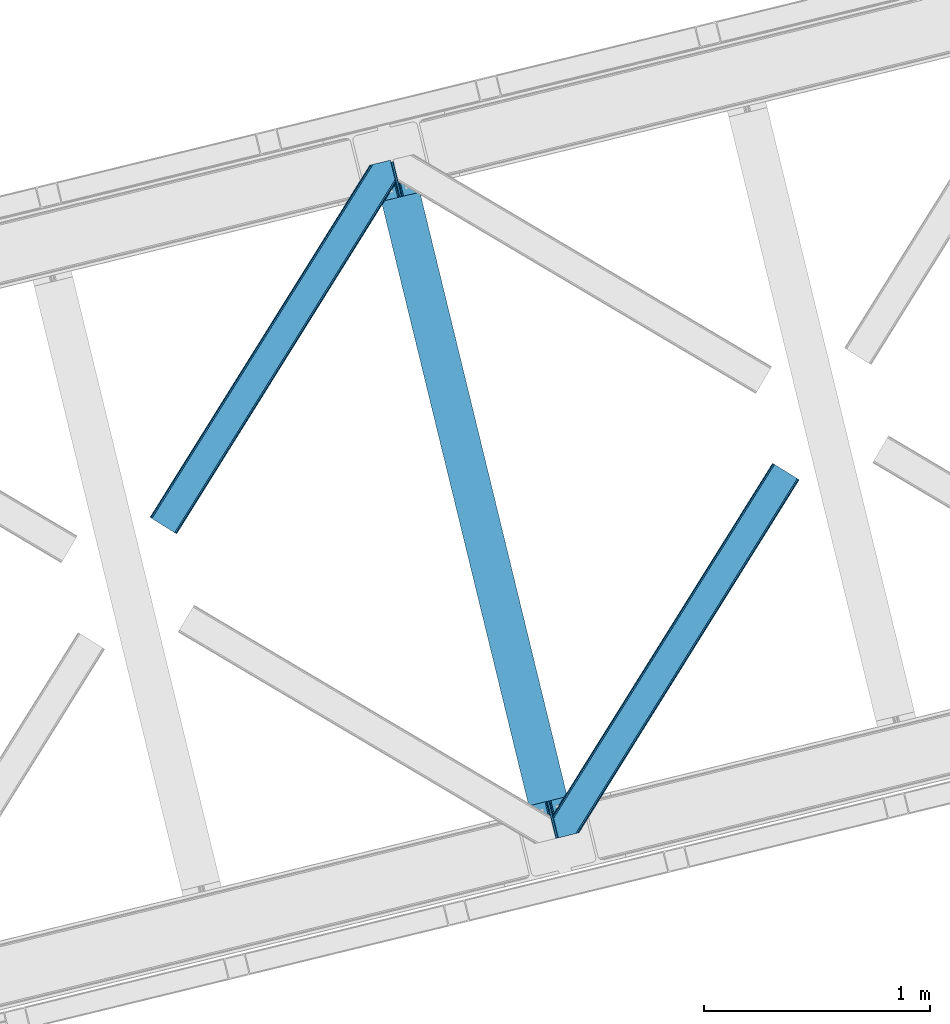
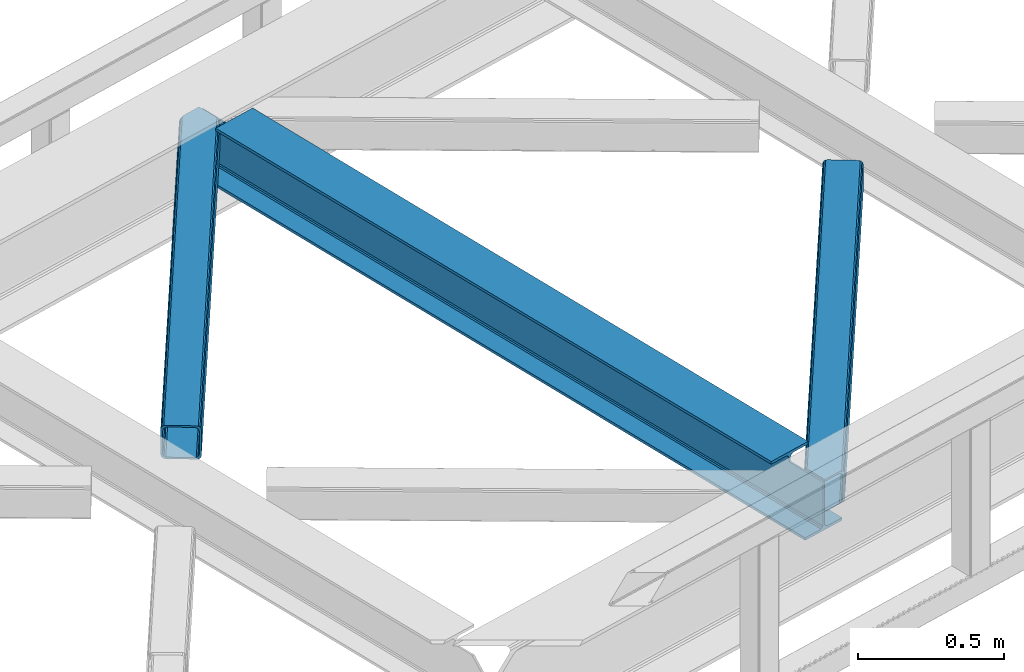
# One storey, part 60 of 92: 2 members, 1 beam.
"""IFC4 building model written with IfcOpenShell, lengths in millimetres."""

from ifc_helpers import new_model, entity, si_unit, converted_unit, derived_unit, direction, frame, origin, place, context, subcontext, project, spatial, triangles, polygons, material, type_object, element, save


model = new_model("IFC4")

# Units and contexts
model_context = context("Model", 3, precision=0.01, world=origin(), true_north=direction((6.12303176911189e-17, 1.0)))
plan_context = context("Plan", 3, precision=0.01, world=origin(), true_north=direction((6.12303176911189e-17, 1.0)))
body_context = subcontext(model_context, "Body", "Model", "MODEL_VIEW")
ifc_project = project(units=[si_unit("LENGTHUNIT", "METRE", prefix="MILLI"), si_unit("AREAUNIT", "SQUARE_METRE"), si_unit("VOLUMEUNIT", "CUBIC_METRE"), converted_unit("PLANEANGLEUNIT", "DEGREE", entity("IfcRatioMeasure", 0.0174532925199433), si_unit("PLANEANGLEUNIT", "RADIAN"), dimensions=[0, 0, 0, 0, 0, 0, 0]), si_unit("MASSUNIT", "GRAM", prefix="KILO"), derived_unit("MASSDENSITYUNIT", [(si_unit("MASSUNIT", "GRAM", prefix="KILO"), 1), (si_unit("LENGTHUNIT", "METRE"), -3)]), derived_unit("MOMENTOFINERTIAUNIT", [(si_unit("LENGTHUNIT", "METRE"), 4)]), si_unit("TIMEUNIT", "SECOND"), si_unit("FREQUENCYUNIT", "HERTZ"), si_unit("THERMODYNAMICTEMPERATUREUNIT", "DEGREE_CELSIUS"), derived_unit("THERMALTRANSMITTANCEUNIT", [(si_unit("MASSUNIT", "GRAM", prefix="KILO"), 1), (si_unit("THERMODYNAMICTEMPERATUREUNIT", "KELVIN"), -1), (si_unit("TIMEUNIT", "SECOND"), -3)]), derived_unit("VOLUMETRICFLOWRATEUNIT", [(si_unit("LENGTHUNIT", "METRE"), 3), (si_unit("TIMEUNIT", "SECOND"), -1)]), derived_unit("MASSFLOWRATEUNIT", [(si_unit("MASSUNIT", "GRAM", prefix="KILO"), 1), (si_unit("TIMEUNIT", "SECOND"), -1)]), derived_unit("ROTATIONALFREQUENCYUNIT", [(si_unit("TIMEUNIT", "SECOND"), -1)]), si_unit("ELECTRICCURRENTUNIT", "AMPERE"), si_unit("ELECTRICVOLTAGEUNIT", "VOLT"), si_unit("POWERUNIT", "WATT"), si_unit("FORCEUNIT", "NEWTON", prefix="KILO"), si_unit("ILLUMINANCEUNIT", "LUX"), si_unit("LUMINOUSFLUXUNIT", "LUMEN"), si_unit("LUMINOUSINTENSITYUNIT", "CANDELA"), derived_unit("USERDEFINED", [(si_unit("MASSUNIT", "GRAM", prefix="KILO"), -1), (si_unit("LENGTHUNIT", "METRE"), -2), (si_unit("TIMEUNIT", "SECOND"), 3), (si_unit("LUMINOUSFLUXUNIT", "LUMEN"), 1)]), derived_unit("LINEARVELOCITYUNIT", [(si_unit("LENGTHUNIT", "METRE"), 1), (si_unit("TIMEUNIT", "SECOND"), -1)]), si_unit("PRESSUREUNIT", "PASCAL"), derived_unit("USERDEFINED", [(si_unit("LENGTHUNIT", "METRE"), -2), (si_unit("MASSUNIT", "GRAM", prefix="KILO"), 1), (si_unit("TIMEUNIT", "SECOND"), -2)]), derived_unit("LINEARFORCEUNIT", [(si_unit("MASSUNIT", "GRAM", prefix="KILO"), 1), (si_unit("LENGTHUNIT", "METRE"), 1), (si_unit("TIMEUNIT", "SECOND"), -2), (si_unit("LENGTHUNIT", "METRE"), -1)]), derived_unit("PLANARFORCEUNIT", [(si_unit("MASSUNIT", "GRAM", prefix="KILO"), 1), (si_unit("LENGTHUNIT", "METRE"), 1), (si_unit("TIMEUNIT", "SECOND"), -2), (si_unit("LENGTHUNIT", "METRE"), -2)])], contexts=[model_context, plan_context])

# Site, building, storey
site_placement = place(None, origin())
site = spatial("IfcSite", under=ifc_project, at=site_placement, CompositionType="ELEMENT")
building_placement = place(site_placement, origin())
building = spatial("IfcBuilding", under=site, at=building_placement, CompositionType="ELEMENT")
storey_placement = place(building_placement, frame((0.0, 0.0, 15900.0)))
storey = spatial("IfcBuildingStorey", under=building, at=storey_placement, Name="05", CompositionType="ELEMENT", Elevation=15900.0)

# Beam
ifc_material = material(Name="Metal painted (White)")
beam_type = type_object("IfcBeamType", PredefinedType="BEAM")
beam_placement = place(storey_placement, frame((-27174.2, 11162.19, 3441.0)))
element("IfcBeam", 1, at=beam_placement, inside=storey, type_object=beam_type, material=ifc_material, ObjectType="Steel Beam", PredefinedType="BEAM", context=body_context, shape_type="Tessellation", body=[
    polygons([(898.85391135252, 41.4445662733103, 11.000000000004), (898.85391135252, 41.4445662733103, 2.16573425859679e-12), (170.021610174761, 3031.3960252037, 2.16573425859679e-12), (170.021610174761, 3031.3960252037, 11.000000000004), (832.788371398898, 25.3403919499656, 11.000000000004), (103.956070221135, 3015.29185088035, 11.000000000004), (826.839621377606, 23.8903211957417, 12.2179274798217), (98.0073201998427, 3013.84178012613, 12.2179274798217), (821.796514621506, 22.6610105689216, 15.6862915010192), (92.9642134437384, 3012.61246949931, 15.6862915010192), (818.42681841833, 21.839611468714, 20.8770650821657), (89.5945172405625, 3011.7910703991, 20.8770650821657), (817.243538468644, 21.5511744621227, 27.0000000000047), (88.4112372908809, 3011.50263339251, 27.0000000000047), (81.6103728838888, 3009.84485074157, 27.0000000000047), (81.6103728838844, 3009.84485074157, 203.000000000006), (88.4112372908766, 3011.50263339251, 203.000000000006), (0.0, 2989.95145893039, 2.16573425859679e-12), (4.33146851719357e-12, 2989.95145893039, 10.9999999999997), (66.0655399536259, 3006.05563325373, 11.000000000004), (72.0142899749184, 3007.50570400796, 12.2179274798217), (77.0573967310183, 3008.73501463478, 15.6862915010192), (80.4270929342029, 3009.55641373498, 20.8770650821613), (817.243538468635, 21.5511744621206, 203.000000000006), (810.442674061647, 19.8933918111876, 203.000000000006), (810.442674061647, 19.8933918111876, 27.0000000000047), (809.259394111961, 19.6049548045963, 20.8770650821613), (805.889697908786, 18.7835557043887, 15.6862915010192), (800.846591152681, 17.5542450775685, 12.2179274798217), (794.897841131384, 16.1041743233425, 11.000000000004), (728.832301177763, 0.0, 10.9999999999997), (728.832301177763, 0.0, 2.16573425859679e-12), (777.543778045845, 184.415062601692, 203.069791966819), (125.888966506596, 2857.75452019162, 203.000000000006), (126.111847295746, 2856.84017775719, 203.617301946336), (126.12476154027, 2856.7871977843, 217.000003693143), (777.398574796916, 185.010597404072, 217.000003676718), (777.399445404814, 185.007025963192, 204.00000679514), (770.833476881403, 182.385463974445, 203.006342981529), (770.610629219866, 183.299815969774, 203.617301946336), (770.597714975338, 183.352795942669, 217.000003693143), (119.323901718691, 2855.1293963229, 217.000003676718), (119.323031110798, 2855.13296776378, 204.00000679514), (119.178731521743, 2855.72494066435, 203.076120467494), (119.088102099604, 2856.09673754069, 203.000000000006), (778.582059520952, 185.298194377514, 223.122939328039), (781.951055929623, 186.122464201393, 228.313710402595), (786.993691333646, 187.353708426697, 231.782072735464), (792.942270204354, 188.804481281379, 232.999999602236), (859.007721069873, 204.909021065315, 232.999999283132), (859.00624773344, 204.915065042188, 243.999994005812), (688.984866829523, 163.469558245298, 243.999994827032), (688.986340165961, 163.463514268424, 233.000000104353), (755.051791031484, 179.568054052358, 232.999999785253), (761.000696159814, 181.017488520584, 231.782072861012), (766.044260666937, 182.244921343716, 228.313710479427), (769.414647576681, 183.063487001148, 223.12293937232), (118.140416994656, 2854.84179934945, 223.122939328039), (114.771420585981, 2854.01752952557, 228.313710402595), (109.728785181961, 2852.78628530027, 231.782072735464), (103.780206311249, 2851.33551244559, 232.999999602236), (37.7147554457342, 2835.23097266165, 232.999999283128), (37.7162287821717, 2835.22492868478, 243.999994005812), (207.737609686088, 2876.67043548167, 243.999994827032), (207.736136349647, 2876.67647945854, 233.000000104357), (141.670685484123, 2860.57193967461, 232.999999785253), (135.721780355793, 2859.12250520639, 231.782072861012), (130.678215848667, 2857.89507238325, 228.313710479427), (127.307828938922, 2857.07650672582, 223.12293937232)], [[[1, 2, 3, 4]], [[5, 1, 4, 6]], [[7, 5, 6, 8]], [[9, 7, 8, 10]], [[11, 9, 10, 12]], [[13, 11, 12, 14]], [[15, 16, 17, 14, 12, 10, 8, 6, 4, 3, 18, 19, 20, 21, 22, 23]], [[13, 24, 25, 26, 27, 28, 29, 30, 31, 32, 2, 1, 5, 7, 9, 11]], [[2, 32, 18, 3]], [[32, 31, 19, 18]], [[31, 30, 20, 19]], [[27, 26, 15, 23]], [[28, 27, 23, 22]], [[29, 28, 22, 21]], [[30, 29, 21, 20]], [[33, 24, 13, 14, 17, 34, 35, 36, 37, 38]], [[25, 39, 40, 41, 42, 43, 44, 16, 15, 26]], [[39, 25, 24, 33]], [[45, 34, 17, 16]], [[41, 40, 38, 37, 46, 47, 48, 49, 50, 51, 52, 53, 54, 55, 56, 57]], [[42, 58, 59, 60, 61, 62, 63, 64, 65, 66, 67, 68, 69, 36, 35, 43]], [[46, 37, 36, 69]], [[47, 46, 69, 68]], [[48, 47, 68, 67]], [[49, 48, 67, 66]], [[50, 49, 66, 65]], [[51, 50, 65, 64]], [[52, 51, 64, 63]], [[53, 52, 63, 62]], [[54, 53, 62, 61]], [[55, 54, 61, 60]], [[56, 55, 60, 59]], [[57, 56, 59, 58]], [[41, 57, 58, 42]]], closed=False),
])

# Members
member_type_1 = type_object("IfcMemberType", PredefinedType="BRACE")
member_1_placement = place(storey_placement, frame((-28160.16, 12527.49, 3510.0)))
element("IfcMember", 2, at=member_1_placement, inside=storey, type_object=member_type_1, ObjectType="Steel Horizontal Brace", PredefinedType="BRACE", context=body_context, shape_type="Tessellation", body=[
    triangles([(933.019793701173, 1535.69230957031, 0.0), (967.780462646486, 1393.09171142578, 0.0), (14.8479309082031, 64.8704589843746, 0.0), (103.9169128418, 9.2680389404286, 0.0), (928.803771972656, 1552.99125366211, 5.49966430664063), (928.943298339844, 1552.41687011719, 5.20782165527635), (930.803649902344, 1544.78710327148, 1.33247680664135), (971.998809814453, 1375.79276733398, 5.49966430664063), (971.856958007815, 1376.36715087891, 5.20782165527635), (969.998931884766, 1383.99691772461, 1.33247680664135), (972.210424804689, 1375.53813171387, 5.85313110351854), (972.424365234376, 1375.28349609375, 6.20659790039281), (928.915393066407, 1553.57028808594, 5.74383544921875), (972.726672363282, 1375.53813171387, 6.35310058594041), (929.029339599612, 1554.1772277832, 5.9996337890625), (973.026654052737, 1375.79276733398, 6.49960327148438), (929.145611572269, 1554.78416748047, 6.25659484863354), (929.254907226565, 1555.36203918457, 6.49960327148438), (4.34857177734375, 71.4223846435543, 5.12526855468968), (1.13248901367479, 73.4315643310547, 10.8028289794929), (973.361517333986, 1630.84347839355, 10.8028289794929), (976.917114257813, 1631.70970458984, 6.49960327148438), (9.16455688476708, 68.415591430663, 1.33247680664135), (971.508142089846, 1630.39118041992, 17.5000946044929), (0.0, 74.1373352050778, 17.5000946044929), (1081.10145263672, 1548.91708374023, 6.49960327148438), (1056.20762329102, 1651.03759460449, 6.49960327148438), (971.508142089846, 1630.39118041992, 122.500662231447), (0.0, 74.1373352050778, 122.500662231447), (973.361517333986, 1630.84347839355, 129.197927856447), (1.13248901367479, 73.4315643310547, 129.197927856447), (978.633288574219, 1632.12828369141, 134.874325561526), (4.34857177734375, 71.4223846435543, 134.874325561526), (986.530480957033, 1634.05374755859, 138.667117309571), (9.16455688476708, 68.415591430663, 138.667117309571), (995.841540527344, 1636.32221374512, 139.999594116212), (14.8479309082031, 64.8704589843746, 139.999594116212), (118.760192871094, 0.0, 17.5000946044929), (117.632354736328, 0.705770874023074, 10.8028289794929), (1085.14306640625, 1551.25066223144, 10.9783996582046), (1087.41734619141, 1552.56453552246, 13.5003387451179), (109.597961425781, 5.7205810546875, 1.33247680664135), (114.413946533205, 2.71495056152344, 5.12526855468968), (1087.57082519531, 1551.93550415039, 17.5000946044929), (1081.77815551758, 1575.70265808105, 139.999594116212), (1063.00953369141, 1652.69563293457, 139.999594116212), (103.9169128418, 9.2680389404286, 139.999594116212), (1083.99429931641, 1566.60670166016, 138.667117309571), (109.597961425781, 5.7205810546875, 138.667117309571), (1085.87325439453, 1558.89670715332, 134.874325561526), (114.413946533205, 2.71495056152344, 134.874325561526), (1087.12899169922, 1553.74469604492, 129.197927856447), (117.632354736328, 0.705770874023074, 129.197927856447), (1087.57082519531, 1551.93550415039, 122.500662231447), (118.760192871094, 0.0, 122.500662231447), (1082.53857421875, 1566.77413330078, 12.1260040283232), (1083.96639404297, 1566.72413635254, 13.5003387451179), (1077.8528137207, 1569.98556518555, 8.3320495605476), (1074.6483581543, 1577.50138549805, 6.99957275390625), (1056.69364013672, 1651.1561920166, 6.99957275390625), (1005.57350463867, 1638.69532470703, 6.99957275390625), (20.784777832032, 61.1625457763676, 6.99957275390625), (97.9777404785164, 12.9736267089847, 6.99957275390625), (108.474774169925, 6.42170104980505, 12.1260040283232), (111.693182373048, 4.41252136230469, 17.8035644531265), (1084.81285400391, 1563.2510925293, 17.8035644531265), (103.661114501956, 9.42849426269458, 8.3320495605476), (1085.25236206055, 1561.44190063477, 24.4996673583992), (112.823345947269, 3.70791320800708, 24.4996673583992), (983.093481445314, 1633.21542663574, 17.8035644531265), (981.240106201174, 1632.76429138184, 24.4996673583992), (7.0693359375, 69.7248138427731, 17.8035644531265), (5.94149780273438, 70.4305847167961, 24.4996673583992), (988.369903564453, 1634.50139465332, 12.1260040283232), (10.2877441406272, 67.7156341552727, 12.1260040283232), (996.262445068362, 1636.42569580078, 8.3320495605476), (15.1037292480469, 64.7100036621086, 8.3320495605476), (981.240106201174, 1632.76429138184, 115.501089477541), (5.94149780273438, 70.4305847167961, 115.501089477541), (996.262445068362, 1636.42569580078, 131.667544555665), (1005.57350463867, 1638.69532470703, 133.000021362306), (1063.00953369141, 1652.69563293457, 133.000021362306), (988.369903564453, 1634.50139465332, 127.87475280762), (983.093481445314, 1633.21542663574, 122.196029663086), (20.784777832032, 61.1625457763676, 133.000021362306), (15.1037292480469, 64.7100036621086, 131.667544555665), (10.2877441406272, 67.7156341552727, 127.87475280762), (7.0693359375, 69.7248138427731, 122.196029663086), (108.474774169925, 6.42170104980505, 127.87475280762), (111.693182373048, 4.41252136230469, 122.196029663086), (112.823345947269, 3.70791320800708, 115.501089477541), (97.9777404785164, 12.9736267089847, 133.000021362306), (103.661114501956, 9.42849426269458, 131.667544555665), (1085.25236206055, 1561.44190063477, 115.501089477541), (1084.81285400391, 1563.2510925293, 122.196029663086), (1083.55711669922, 1568.40310363769, 127.87475280762), (1081.67583618164, 1576.11309814453, 131.667544555665), (1079.45969238281, 1585.20905456543, 133.000021362306)], [[1, 2, 3], [4, 3, 2], [1, 5, 2], [6, 5, 1], [1, 7, 6], [2, 5, 8], [8, 9, 2], [10, 2, 9], [11, 8, 5], [12, 11, 13], [14, 12, 15], [16, 14, 17], [17, 18, 16], [15, 17, 14], [13, 15, 12], [5, 13, 11], [17, 19, 18], [19, 17, 15], [13, 19, 15], [19, 13, 5], [5, 6, 19], [20, 21, 18], [18, 19, 20], [21, 22, 18], [19, 6, 7], [7, 1, 23], [3, 23, 1], [7, 23, 19], [24, 21, 20], [20, 25, 24], [18, 26, 16], [26, 18, 22], [27, 26, 22], [28, 24, 29], [25, 29, 24], [30, 28, 31], [29, 31, 28], [32, 30, 33], [31, 33, 30], [34, 32, 35], [33, 35, 32], [36, 34, 37], [35, 37, 34], [38, 39, 40], [40, 41, 38], [42, 10, 9], [39, 12, 16], [16, 40, 39], [16, 26, 40], [9, 39, 43], [9, 12, 39], [9, 43, 42], [2, 10, 4], [42, 4, 10], [41, 44, 38], [45, 36, 37], [36, 45, 46], [37, 47, 45], [48, 45, 47], [47, 49, 48], [50, 48, 49], [49, 51, 50], [52, 50, 51], [51, 53, 52], [54, 52, 53], [53, 55, 54], [44, 54, 38], [55, 38, 54], [56, 40, 26], [41, 40, 56], [56, 57, 41], [58, 26, 59], [26, 58, 56], [60, 59, 26], [59, 61, 62], [61, 59, 60], [62, 63, 59], [64, 65, 66], [66, 57, 64], [58, 59, 63], [63, 67, 58], [56, 58, 67], [67, 64, 56], [57, 56, 64], [68, 66, 65], [65, 69, 68], [70, 71, 72], [73, 72, 71], [74, 70, 75], [72, 75, 70], [76, 74, 77], [75, 77, 74], [61, 76, 62], [77, 62, 76], [71, 78, 73], [79, 73, 78], [34, 36, 80], [46, 81, 36], [81, 46, 82], [81, 80, 36], [83, 34, 80], [83, 32, 34], [32, 84, 30], [84, 32, 83], [28, 84, 78], [84, 28, 30], [61, 22, 76], [70, 74, 22], [74, 76, 22], [61, 60, 22], [71, 70, 24], [21, 24, 70], [28, 71, 24], [71, 28, 78], [70, 22, 21], [80, 81, 85], [85, 86, 80], [83, 80, 86], [86, 87, 83], [84, 83, 87], [87, 88, 84], [78, 84, 88], [88, 79, 78], [53, 89, 90], [91, 38, 55], [53, 90, 55], [53, 51, 89], [90, 91, 55], [89, 51, 49], [92, 47, 37], [47, 93, 49], [93, 47, 92], [93, 89, 49], [39, 64, 43], [69, 38, 91], [38, 65, 39], [65, 38, 69], [39, 65, 64], [4, 63, 3], [42, 43, 64], [64, 67, 42], [67, 63, 4], [4, 42, 67], [87, 35, 33], [37, 85, 92], [37, 86, 85], [86, 37, 35], [87, 86, 35], [79, 29, 25], [31, 88, 87], [33, 31, 87], [88, 31, 29], [79, 88, 29], [23, 75, 19], [3, 63, 62], [62, 77, 3], [77, 75, 23], [23, 3, 77], [20, 19, 75], [25, 73, 79], [72, 25, 20], [25, 72, 73], [72, 20, 75], [66, 41, 57], [54, 44, 68], [44, 66, 68], [68, 94, 54], [44, 41, 66], [95, 54, 94], [52, 54, 95], [50, 95, 96], [95, 50, 52], [96, 48, 50], [97, 48, 96], [97, 98, 45], [97, 45, 48], [98, 46, 45], [98, 82, 46], [81, 98, 85], [81, 82, 98], [92, 85, 98], [95, 94, 90], [91, 90, 94], [96, 95, 89], [90, 89, 95], [97, 96, 93], [89, 93, 96], [98, 97, 92], [93, 92, 97], [94, 68, 91], [69, 91, 68]]),
])
member_type_2 = type_object("IfcMemberType", PredefinedType="BRACE")
member_2_placement = place(storey_placement, frame((-26379.09, 11184.33, 3510.0)))
element("IfcMember", 3, at=member_2_placement, inside=storey, type_object=member_type_2, ObjectType="Steel Horizontal Brace", PredefinedType="BRACE", context=body_context, shape_type="Tessellation", body=[
    triangles([(986.153759765624, 1647.42967529297, 0.0), (1075.22274169922, 1591.82725524902, 0.0), (119.788037109374, 259.603921508789, 0.0), (154.548706054688, 117.003323364259, 0.0), (115.902227783201, 275.544808959961, 4.52065429687718), (117.571893310545, 268.698715209961, 1.33247680664135), (158.434515380857, 101.062435913087, 4.52065429687718), (156.764849853513, 107.908529663086, 1.33247680664135), (114.825549316403, 275.742471313477, 5.52059326172093), (115.130181884764, 275.923855590821, 5.35316162109666), (158.132208251951, 99.1218566894531, 5.27525939941552), (115.439465332031, 276.107565307617, 5.18107910156323), (158.232202148436, 99.7776306152355, 5.02062377929906), (158.188018798828, 99.4822998046875, 5.13573303222802), (115.541784667967, 276.1680267334, 5.12526855468968), (115.683636474609, 275.921530151367, 4.88574829101708), (158.336846923827, 100.433404541016, 4.76482543945531), (158.032214355466, 98.4928253173839, 5.52059326172093), (1085.71977539062, 1585.27416687012, 5.12526855468968), (1080.90146484375, 1588.28096008301, 1.33247680664135), (1088.93818359375, 1583.26498718262, 10.8028289794929), (114.21163330078, 21.8533172607422, 10.8028289794929), (109.467736816405, 20.6964111328125, 5.52059326172093), (1090.06602172851, 1582.56037902832, 17.5000946044929), (116.062683105469, 22.3044525146488, 17.5000946044929), (6.75307617187354, 102.619317626953, 5.52059326172093), (31.3632019042961, 1.65803833007885, 5.52059326172093), (1090.06602172851, 1582.56037902832, 122.500662231447), (116.062683105469, 22.3044525146488, 122.500662231447), (1088.93818359375, 1583.26498718262, 129.197927856447), (114.21163330078, 21.8533172607422, 129.197927856447), (1085.71977539062, 1585.27416687012, 134.874325561526), (108.935211181641, 20.5673492431652, 134.874325561526), (1080.90146484375, 1588.28096008301, 138.667117309571), (101.042669677732, 18.6430480957042, 138.667117309571), (1075.22274169922, 1591.82725524902, 139.999594116212), (91.7292846679666, 16.3722564697273, 139.999594116212), (980.472711181639, 1650.97597045899, 1.33247680664135), (975.656726074216, 1653.98276367187, 5.12526855468968), (1.69059448242115, 100.411312866212, 10.9621215820334), (972.438317871092, 1655.99078063965, 10.8028289794929), (971.308154296872, 1656.69655151367, 17.5000946044929), (0.239520263668965, 99.7776306152355, 12.5201660156272), (0.0, 100.760128784181, 17.5000946044929), (5.79266967773219, 76.9941375732433, 139.999594116212), (986.153759765624, 1647.42967529297, 139.999594116212), (24.5612915039055, 0.0, 139.999594116212), (971.308154296872, 1656.69655151367, 122.500662231447), (0.0, 100.760128784181, 122.500662231447), (980.472711181639, 1650.97597045899, 138.667117309571), (3.57652587890334, 86.0889312744148, 138.667117309571), (975.656726074216, 1653.98276367187, 134.874325561526), (1.69524536132667, 93.7989257812496, 134.874325561526), (972.438317871092, 1655.99078063965, 129.197927856447), (0.43950805663917, 98.9509368896488, 129.197927856447), (29.9237548828096, 1.30689697265734, 6.99957275390625), (12.1969299316406, 74.0326904296871, 6.99957275390625), (8.99247436523365, 81.5485107421882, 8.3320495605476), (3.88580932616969, 84.8122650146488, 12.5201660156272), (1069.28589477539, 1595.53400573731, 6.99957275390625), (81.9949951171875, 14.0003082275398, 6.99957275390625), (992.090606689453, 1643.72292480469, 6.99957275390625), (981.593572998045, 1650.27601318359, 12.1260040283232), (978.375164794921, 1652.28403015137, 17.8035644531265), (2.75797119140407, 89.4445404052731, 17.8035644531265), (986.409558105468, 1647.2692199707, 8.3320495605476), (977.245001220701, 1652.98980102539, 24.4996673583992), (2.31613769531032, 91.2537322998051, 24.4996673583992), (977.245001220701, 1652.98980102539, 115.501089477541), (2.31613769531032, 91.2537322998051, 115.501089477541), (4.01370849609157, 84.2925292968757, 127.87475280762), (2.75797119140407, 89.4445404052731, 122.196029663086), (5.89266357421729, 76.5825347900391, 131.667544555665), (8.10880737304615, 67.4865783691403, 133.000021362306), (24.5612915039055, 0.0, 133.000021362306), (978.375164794921, 1652.28403015137, 122.196029663086), (981.593572998045, 1650.27601318359, 127.87475280762), (986.409558105468, 1647.2692199707, 131.667544555665), (992.090606689453, 1643.72292480469, 133.000021362306), (1069.28589477539, 1595.53400573731, 133.000021362306), (81.9949951171875, 14.0003082275398, 133.000021362306), (1079.78060302734, 1588.9809173584, 12.1260040283232), (1082.99901123047, 1586.97290039063, 17.8035644531265), (1084.12917480469, 1586.2671295166, 24.4996673583992), (1074.96461791992, 1591.98771057129, 8.3320495605476), (1079.78060302734, 1588.9809173584, 127.87475280762), (1084.12917480469, 1586.2671295166, 115.501089477541), (1082.99901123047, 1586.97290039063, 122.196029663086), (1074.96461791992, 1591.98771057129, 131.667544555665), (91.3083801269531, 16.2699371337894, 131.667544555665), (99.2032470703125, 18.1942382812504, 127.87475280762), (104.477343749997, 19.4802062988292, 122.196029663086), (106.330718994141, 19.9325042724613, 115.501089477541), (91.3083801269531, 16.2699371337894, 8.3320495605476), (104.477343749997, 19.4802062988292, 17.8035644531265), (99.2032470703125, 18.1942382812504, 12.1260040283232), (106.330718994141, 19.9325042724613, 24.4996673583992)], [[1, 2, 3], [4, 3, 2], [5, 3, 4], [3, 5, 6], [4, 7, 5], [7, 4, 8], [9, 10, 11], [10, 12, 13], [13, 14, 10], [12, 15, 16], [16, 17, 12], [16, 5, 7], [7, 17, 16], [17, 13, 12], [14, 11, 10], [11, 18, 9], [19, 14, 13], [13, 20, 19], [13, 17, 20], [17, 7, 20], [7, 8, 20], [21, 22, 18], [18, 19, 21], [14, 19, 11], [18, 11, 19], [22, 23, 18], [21, 24, 25], [25, 22, 21], [2, 20, 4], [8, 4, 20], [23, 26, 18], [23, 27, 26], [9, 18, 26], [24, 28, 29], [29, 25, 24], [28, 30, 29], [31, 29, 30], [30, 32, 31], [33, 31, 32], [32, 34, 33], [35, 33, 34], [34, 36, 35], [37, 35, 36], [38, 6, 5], [5, 39, 38], [5, 15, 39], [40, 41, 9], [41, 39, 15], [42, 41, 40], [40, 43, 42], [43, 44, 42], [9, 26, 40], [38, 1, 6], [3, 6, 1], [36, 45, 37], [36, 46, 45], [45, 47, 37], [48, 42, 44], [44, 49, 48], [46, 50, 51], [51, 45, 46], [50, 52, 53], [53, 51, 50], [52, 54, 55], [55, 53, 52], [54, 48, 49], [49, 55, 54], [27, 56, 57], [26, 57, 58], [57, 26, 27], [59, 40, 26], [26, 58, 59], [43, 40, 59], [60, 57, 61], [60, 62, 57], [57, 56, 61], [63, 64, 65], [65, 59, 63], [66, 63, 59], [62, 66, 58], [58, 57, 62], [59, 58, 66], [64, 67, 68], [68, 65, 64], [67, 69, 70], [70, 68, 67], [71, 53, 72], [73, 74, 45], [74, 47, 45], [74, 75, 47], [51, 73, 45], [71, 51, 53], [71, 73, 51], [49, 68, 70], [55, 72, 53], [70, 72, 49], [72, 55, 49], [44, 68, 49], [43, 59, 65], [65, 68, 44], [44, 43, 65], [69, 76, 70], [72, 70, 76], [76, 77, 72], [71, 72, 77], [77, 78, 71], [73, 71, 78], [78, 79, 73], [74, 73, 79], [80, 74, 79], [74, 80, 81], [75, 74, 81], [21, 82, 83], [84, 28, 24], [21, 83, 24], [21, 19, 82], [83, 84, 24], [82, 19, 20], [60, 2, 1], [2, 85, 20], [85, 2, 60], [85, 82, 20], [30, 86, 32], [87, 28, 84], [28, 88, 30], [88, 28, 87], [30, 88, 86], [36, 80, 46], [34, 32, 86], [86, 89, 34], [89, 80, 36], [36, 34, 89], [63, 38, 39], [1, 62, 60], [1, 66, 62], [66, 1, 38], [63, 66, 38], [67, 42, 48], [41, 64, 63], [39, 41, 63], [64, 41, 42], [67, 64, 42], [50, 77, 52], [46, 80, 79], [79, 78, 46], [78, 77, 50], [50, 46, 78], [54, 52, 77], [48, 69, 67], [76, 48, 54], [48, 76, 69], [76, 54, 77], [35, 37, 90], [47, 81, 37], [81, 47, 75], [81, 90, 37], [91, 35, 90], [91, 33, 35], [33, 92, 31], [92, 33, 91], [29, 92, 93], [92, 29, 31], [61, 23, 94], [95, 96, 23], [96, 94, 23], [61, 27, 23], [27, 61, 56], [97, 95, 25], [22, 25, 95], [29, 97, 25], [97, 29, 93], [95, 23, 22], [80, 89, 90], [90, 81, 80], [89, 86, 91], [91, 90, 89], [86, 88, 92], [92, 91, 86], [88, 87, 93], [93, 92, 88], [87, 84, 97], [97, 93, 87], [84, 83, 97], [95, 97, 83], [83, 82, 95], [96, 95, 82], [82, 85, 96], [94, 96, 85], [85, 60, 94], [61, 94, 60]]),
])

save(model, "model.ifc")
